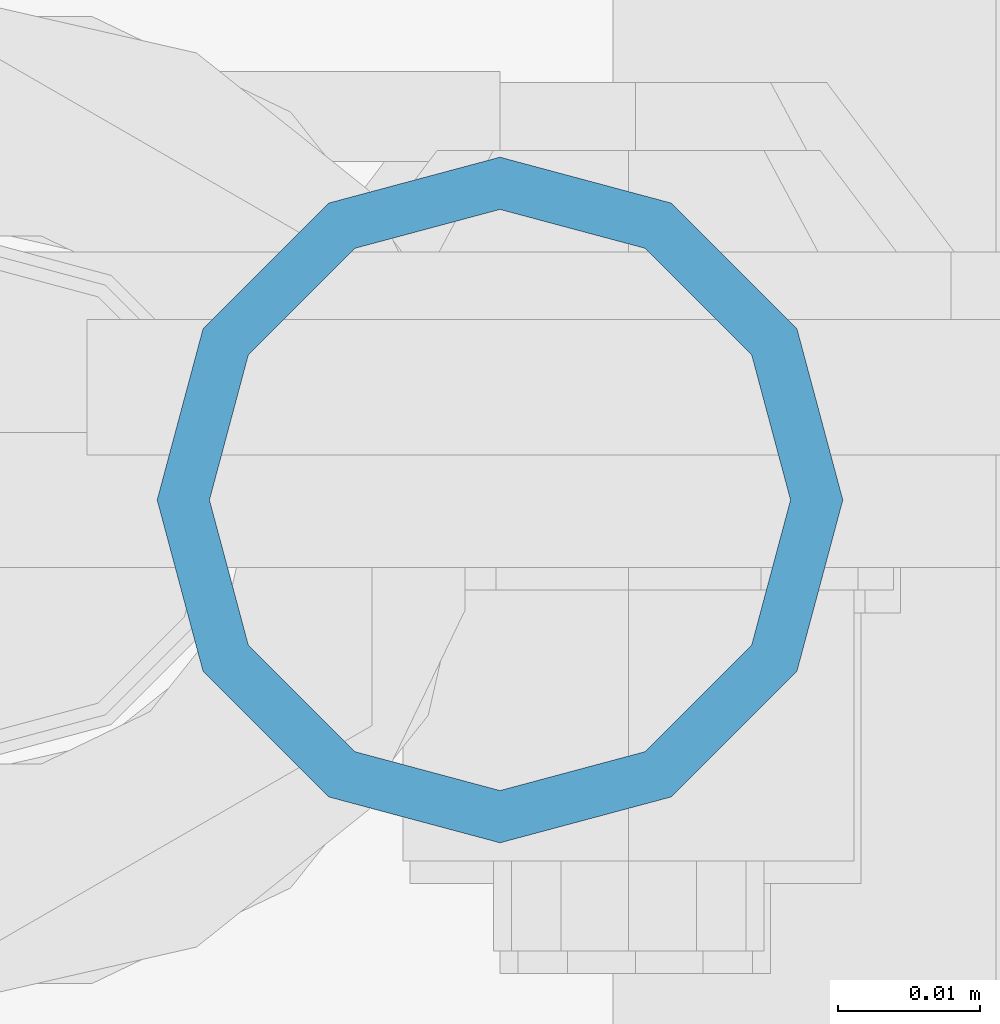
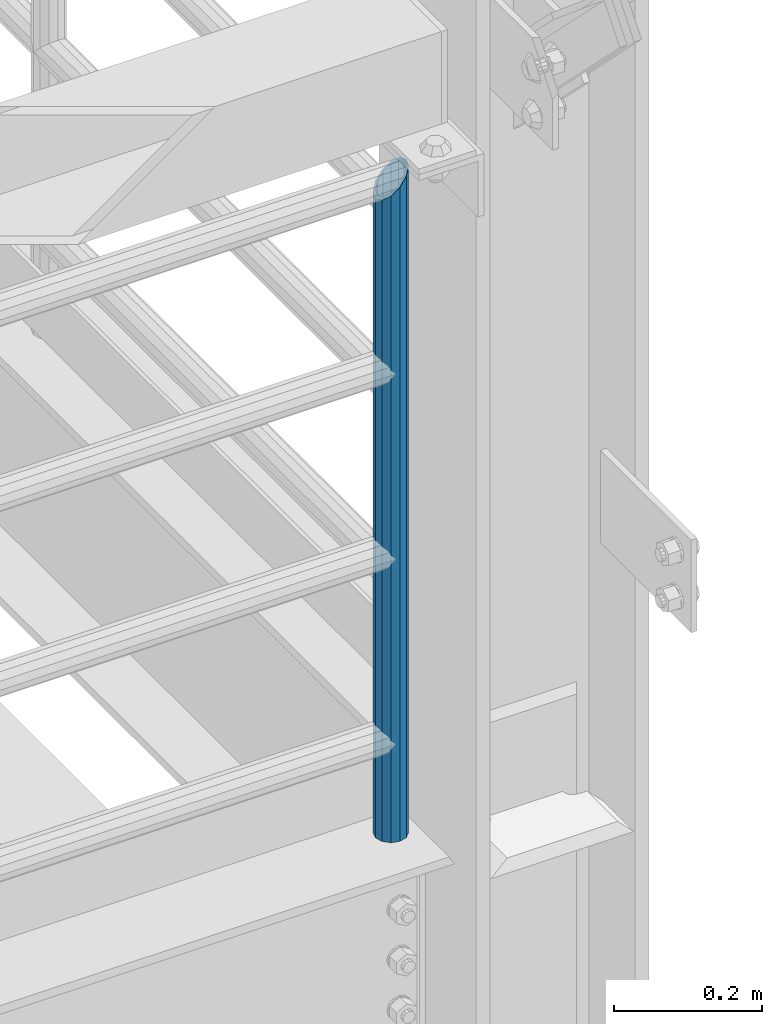
# One storey, part 588 of 1876: 1 column, 1 element without a shape of its own.
"""IFC2X3 building model written with IfcOpenShell, lengths in millimetres."""

from ifc_helpers import new_model, si_unit, frame, origin_with_axes, place, context, subcontext, project, spatial, faceted_brep, material, type_object, element, aggregate, save


model = new_model("IFC2X3")

# Units and contexts
model_context = context("Model", 3, precision=1e-05, world=origin_with_axes())
body_context = subcontext(model_context, "Body", "Model", "MODEL_VIEW")
ifc_project = project(units=[si_unit("LENGTHUNIT", "METRE", prefix="MILLI"), si_unit("AREAUNIT", "SQUARE_METRE"), si_unit("VOLUMEUNIT", "CUBIC_METRE"), si_unit("MASSUNIT", "GRAM", prefix="KILO"), si_unit("TIMEUNIT", "SECOND"), si_unit("PLANEANGLEUNIT", "RADIAN"), si_unit("SOLIDANGLEUNIT", "STERADIAN"), si_unit("THERMODYNAMICTEMPERATUREUNIT", "DEGREE_CELSIUS"), si_unit("LUMINOUSINTENSITYUNIT", "LUMEN")], contexts=[model_context])

# Site, building, storey
site_placement = place(None, origin_with_axes())
site = spatial("IfcSite", under=ifc_project, at=site_placement, CompositionType="ELEMENT")
building_placement = place(site_placement, origin_with_axes())
building = spatial("IfcBuilding", under=site, at=building_placement, Name="Undefined", CompositionType="ELEMENT")
storey_placement = place(building_placement, origin_with_axes())
storey = spatial("IfcBuildingStorey", under=building, at=storey_placement, Name="Undefined", CompositionType="ELEMENT", Elevation=0.0)

# Assembly, column
assembly_placement = place(storey_placement, origin_with_axes())
assembly = element("IfcElementAssembly", 1, at=assembly_placement, inside=storey, Name="RAIL", AssemblyPlace="NOTDEFINED", PredefinedType="RIGID_FRAME")
ifc_material = material()
column_type = type_object("IfcColumnType", Name="PIPE1-1/2SCH40", PredefinedType="NOTDEFINED")
column_placement = place(assembly_placement, frame((7427.9125, -7112.0, 5130.79999999999), z_axis=(0.0, 1.0, 0.0), x_axis=(0.0, 0.0, 1.0)))
column = element("IfcColumn", 2, at=column_placement, type_object=column_type, material=ifc_material, Name="POST", ObjectType="PIPE1-1/2SCH40", context=body_context, shape_type="Brep", body=[
    faceted_brep([(0.0, -20.4469999999999, 0.0), (0.0, -17.7076214311803, 10.2235000000001), (1058.61737856882, -17.7076214311803, 10.2235000000001), (1055.878, -20.4469999999999, 0.0), (0.0, -10.2235000000001, 17.7076214311801), (1066.1015, -10.2235000000001, 17.7076214311801), (-1.45519152283669e-11, 0.0, 20.4470000000001), (1076.325, 0.0, 20.4470000000001), (0.0, 10.2235000000001, 17.7076214311801), (1086.5485, 10.2235000000001, 17.7076214311801), (0.0, 17.7076214311803, 10.2235000000001), (1094.03262143118, 17.7076214311803, 10.2235000000001), (0.0, 20.4469999999999, 0.0), (1096.772, 20.4469999999999, 0.0), (0.0, 17.7076214311803, -10.2235000000001), (1094.03262143118, 17.7076214311803, -10.2235000000001), (0.0, 10.2235000000001, -17.7076214311801), (1086.5485, 10.2235000000001, -17.7076214311801), (-1.45519152283669e-11, 0.0, -20.4470000000001), (1076.325, 0.0, -20.4470000000001), (0.0, -10.2235000000001, -17.7076214311801), (1066.1015, -10.2235000000001, -17.7076214311801), (0.0, -17.7076214311803, -10.2235000000001), (1058.61737856882, -17.7076214311803, -10.2235000000001), (0.0, -24.1299999999992, 0.0), (0.0, -20.8971929933184, -12.0649999999996), (1055.42780700668, -20.8971929933184, -12.0649999999996), (1052.195, -24.1300000000001, 0.0), (0.0, -12.0650000000001, -20.8971929933186), (1064.26, -12.0650000000001, -20.8971929933186), (-1.45519152283669e-11, 0.0, -24.130000000001), (1076.325, 0.0, -24.1300000000001), (0.0, 12.0650000000001, -20.8971929933186), (1088.39, 12.0650000000001, -20.8971929933186), (0.0, 20.8971929933184, -12.0649999999996), (1097.22219299332, 20.8971929933184, -12.0649999999996), (0.0, 24.1299999999992, 0.0), (1100.455, 24.1300000000001, 0.0), (0.0, 20.8971929933184, 12.0649999999996), (1097.22219299332, 20.8971929933184, 12.0649999999996), (0.0, 12.0650000000001, 20.8971929933186), (1088.39, 12.0650000000001, 20.8971929933186), (-1.45519152283669e-11, 0.0, 24.130000000001), (1076.325, 0.0, 24.1300000000001), (0.0, -12.0650000000001, 20.8971929933186), (1064.26, -12.0650000000001, 20.8971929933186), (0.0, -20.8971929933184, 12.0649999999996), (1055.42780700668, -20.8971929933184, 12.0649999999996)], [[[0, 1, 2, 3]], [[1, 4, 5, 2]], [[4, 6, 7, 5]], [[6, 8, 9, 7]], [[8, 10, 11, 9]], [[10, 12, 13, 11]], [[12, 14, 15, 13]], [[14, 16, 17, 15]], [[16, 18, 19, 17]], [[18, 20, 21, 19]], [[20, 22, 23, 21]], [[22, 0, 3, 23]], [[24, 25, 26, 27]], [[25, 28, 29, 26]], [[28, 30, 31, 29]], [[30, 32, 33, 31]], [[32, 34, 35, 33]], [[34, 36, 37, 35]], [[36, 38, 39, 37]], [[38, 40, 41, 39]], [[40, 42, 43, 41]], [[42, 44, 45, 43]], [[44, 46, 47, 45]], [[46, 24, 27, 47]], [[29, 31, 33, 35, 37, 39, 41, 43, 45, 47, 27, 26], [5, 7, 9, 11, 13, 15, 17, 19, 21, 23, 3, 2]], [[46, 44, 42, 40, 38, 36, 34, 32, 30, 28, 25, 24], [22, 20, 18, 16, 14, 12, 10, 8, 6, 4, 1, 0]]]),
])
aggregate(assembly, [column])

save(model, "model.ifc")
